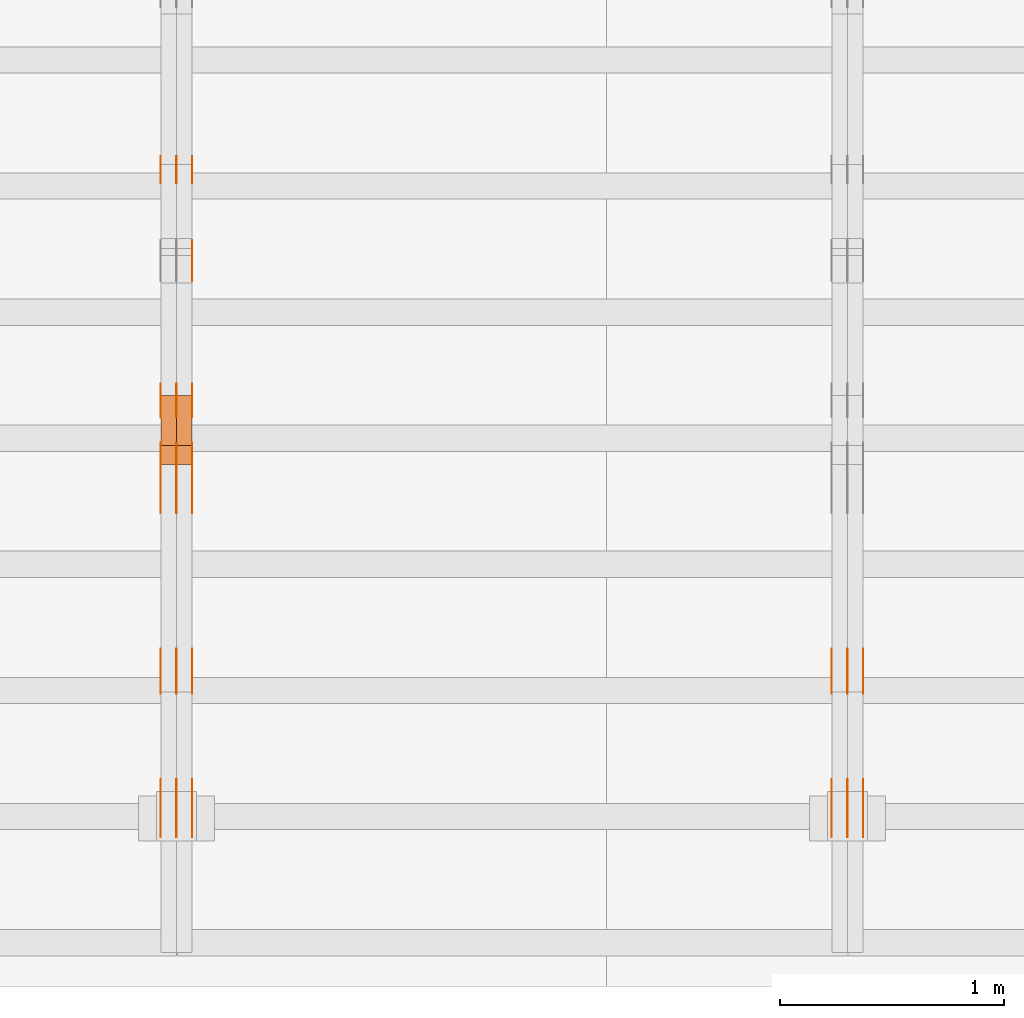
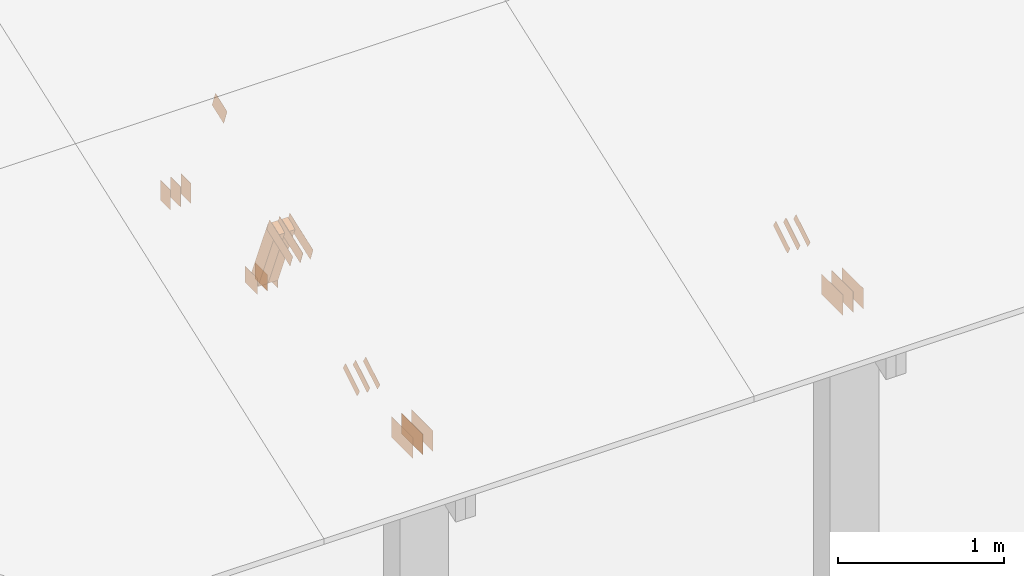
# One storey, part 84 of 189: 31 proxies.
"""IFC2X3 building model written with IfcOpenShell, lengths in millimetres."""

import ifcopenshell
import ifcopenshell.guid

model = None  # the IFC model being written
_history = None  # IfcOwnerHistory: only IFC2X3 demands one
_inside = {}  # id of a spatial element -> (the spatial element, [elements in it])
_under = {}  # id of a project, library or spatial element -> (it, [spatial elements below it])
_declared = {}  # id of a project -> (the project, [libraries it declares])
_typed = {}  # id of a type object -> (the type object, [elements of that type])
_made_of = {}  # id of a material, layer set ... -> (it, [elements and type objects made of it])


def new_model(schema):
    """Start an empty IFC model of exactly this schema.

    Asked for "IFC4X3", IfcOpenShell would pick the latest addendum, in which some entities
    have other attributes; the version numbers below select the first issue.
    IFC2X3 requires an IfcOwnerHistory on every rooted entity: one is made here for all.
    """
    global model, _history
    if schema == "IFC4X3":
        model = ifcopenshell.file(schema_version=(4, 3, 0, 0))
    else:
        model = ifcopenshell.file(schema=schema)
    _inside.clear()
    _under.clear()
    _declared.clear()
    _typed.clear()
    _made_of.clear()
    _history = None
    if model.schema == "IFC2X3":
        org = make("IfcOrganization", Name="unknown")
        user = make(
            "IfcPersonAndOrganization",
            ThePerson=make("IfcPerson", FamilyName="unknown"),
            TheOrganization=org,
        )
        app = make(
            "IfcApplication",
            ApplicationDeveloper=org,
            Version="unknown",
            ApplicationFullName="unknown",
            ApplicationIdentifier="unknown",
        )
        _history = make(
            "IfcOwnerHistory",
            OwningUser=user,
            OwningApplication=app,
            ChangeAction="ADDED",
            CreationDate=0,
        )
    return model


def make(cls, **values):
    """One entity of the class cls with the attributes given. An attribute that is None is left unset."""
    return model.create_entity(
        cls, **{name: value for name, value in values.items() if value is not None}
    )


def entity(cls, *values):
    """Any entity or typed value of the class cls, its attributes in the order of the schema. None: left unset."""
    e = model.create_entity(cls)
    for i, value in enumerate(values):
        if value is not None:
            e[i] = value
    return e


def rooted(cls, **values):
    """An entity with a GlobalId (a new one), such as an element, a storey or a relation."""
    return make(cls, GlobalId=ifcopenshell.guid.new(), OwnerHistory=_history, **values)


def si_unit(unit_type, name, prefix=None):
    """IfcSIUnit, for example si_unit("LENGTHUNIT", "METRE", prefix="MILLI")."""
    return make("IfcSIUnit", UnitType=unit_type, Prefix=prefix, Name=name)


def converted_unit(unit_type, name, factor, base, dimensions=None, offset=None):
    """IfcConversionBasedUnit, such as the inch: factor (a typed value) times the base unit."""
    return make(
        "IfcConversionBasedUnit"
        if offset is None
        else "IfcConversionBasedUnitWithOffset",
        ConversionOffset=offset,
        Dimensions=None
        if dimensions is None
        else entity("IfcDimensionalExponents", *dimensions),
        UnitType=unit_type,
        Name=name,
        ConversionFactor=make(
            "IfcMeasureWithUnit", ValueComponent=factor, UnitComponent=base
        ),
    )


def derived_unit(unit_type, elements):
    """IfcDerivedUnit: a product of units, each with its exponent."""
    return make(
        "IfcDerivedUnit",
        Elements=[
            make("IfcDerivedUnitElement", Unit=unit, Exponent=power)
            for unit, power in elements
        ],
        UnitType=unit_type,
    )


def assignment(units):
    """IfcUnitAssignment: the units of a project."""
    return None if units is None else make("IfcUnitAssignment", Units=units)


def point(xyz):
    """IfcCartesianPoint."""
    return None if xyz is None else make("IfcCartesianPoint", Coordinates=xyz)


def direction(xyz):
    """IfcDirection."""
    return None if xyz is None else make("IfcDirection", DirectionRatios=xyz)


def frame(location, z_axis=None, x_axis=None):
    """IfcAxis2Placement3D, a coordinate frame: its origin and axes. An axis left out is left unset."""
    return make(
        "IfcAxis2Placement3D",
        Location=point(location),
        Axis=direction(z_axis),
        RefDirection=direction(x_axis),
    )


def frame_2d(location, x_axis=None):
    """IfcAxis2Placement2D, a coordinate frame in the plane: its origin and x axis."""
    return make(
        "IfcAxis2Placement2D", Location=point(location), RefDirection=direction(x_axis)
    )


def origin():
    """The frame at (0, 0, 0) with its axes left unset."""
    return frame((0.0, 0.0, 0.0))


def origin_2d_with_axis():
    """The frame at (0, 0) in the plane with the x axis (1, 0) written out."""
    return frame_2d((0.0, 0.0), x_axis=(1.0, 0.0))


def place(relative_to, where):
    """IfcLocalPlacement: puts the frame where relative to a parent placement (None: the world)."""
    return make(
        "IfcLocalPlacement", PlacementRelTo=relative_to, RelativePlacement=where
    )


def context(
    kind, dimensions, precision=None, world=None, true_north=None, identifier=None
):
    """IfcGeometricRepresentationContext, for example the 3D "Model" context."""
    return make(
        "IfcGeometricRepresentationContext",
        ContextIdentifier=identifier,
        ContextType=kind,
        CoordinateSpaceDimension=dimensions,
        Precision=precision,
        WorldCoordinateSystem=world,
        TrueNorth=true_north,
    )


def subcontext(parent, identifier, kind, view, scale=None):
    """IfcGeometricRepresentationSubContext, for example "Body" below "Model"."""
    return make(
        "IfcGeometricRepresentationSubContext",
        ContextIdentifier=identifier,
        ContextType=kind,
        ParentContext=parent,
        TargetScale=scale,
        TargetView=view,
    )


def project(units=None, contexts=None):
    """IfcProject with its units and contexts."""
    return rooted(
        "IfcProject",
        Name="project",
        RepresentationContexts=contexts,
        UnitsInContext=assignment(units),
    )


def spatial(cls, under=None, at=None, **own):
    """A site, building, storey or space (cls), placed at a placement, below another one or the project."""
    s = rooted(cls, ObjectPlacement=at, **own)
    if under is not None:
        _under.setdefault(under.id(), (under, []))[1].append(s)
    return s


def polyline(points):
    """IfcPolyline through the points."""
    return make("IfcPolyline", Points=[point(p) for p in points])


def profile(cls, at=None, kind="AREA", **sizes):
    """A parametric profile (cls). Its sizes go by their IFC names, for example OverallWidth=200.0."""
    return make(cls, ProfileType=kind, Position=at, **sizes)


def rectangle(**sizes):
    """IfcRectangleProfileDef."""
    return profile("IfcRectangleProfileDef", **sizes)


def outline(outer, holes=None, kind="AREA"):
    """IfcArbitraryClosedProfileDef: a profile drawn as a closed curve; with holes, ...WithVoids."""
    if holes is None:
        return make("IfcArbitraryClosedProfileDef", ProfileType=kind, OuterCurve=outer)
    return make(
        "IfcArbitraryProfileDefWithVoids",
        ProfileType=kind,
        OuterCurve=outer,
        InnerCurves=holes,
    )


def extrude(swept, where, along, depth):
    """IfcExtrudedAreaSolid: the profile swept, set in the frame where, extruded along a direction by depth."""
    return make(
        "IfcExtrudedAreaSolid",
        SweptArea=swept,
        Position=where,
        ExtrudedDirection=direction(along),
        Depth=depth,
    )


def shape(context_of_items, identifier, shape_type, items):
    """IfcShapeRepresentation: the items that make up one representation, for example the "Body"."""
    return make(
        "IfcShapeRepresentation",
        ContextOfItems=context_of_items,
        RepresentationIdentifier=identifier,
        RepresentationType=shape_type,
        Items=items,
    )


def source(mapping_origin, context_of_items, identifier, shape_type, items):
    """IfcRepresentationMap: a shape defined once, which mapped items show again and again."""
    return make(
        "IfcRepresentationMap",
        MappingOrigin=mapping_origin,
        MappedRepresentation=shape(context_of_items, identifier, shape_type, items),
    )


def transform(
    local_origin,
    x_axis=None,
    y_axis=None,
    z_axis=None,
    scale=None,
    scale2=None,
    scale3=None,
    uniform=True,
):
    """IfcCartesianTransformationOperator3D, or its non-uniform kind. x_axis, y_axis, z_axis: its Axis1, 2, 3."""
    if uniform:
        return make(
            "IfcCartesianTransformationOperator3D",
            Axis1=direction(x_axis),
            Axis2=direction(y_axis),
            LocalOrigin=point(local_origin),
            Scale=scale,
            Axis3=direction(z_axis),
        )
    return make(
        "IfcCartesianTransformationOperator3DnonUniform",
        Axis1=direction(x_axis),
        Axis2=direction(y_axis),
        LocalOrigin=point(local_origin),
        Scale=scale,
        Axis3=direction(z_axis),
        Scale2=scale2,
        Scale3=scale3,
    )


def mapped(mapping_source, mapping_target):
    """IfcMappedItem: shows the shape of a source again, moved by a transform."""
    return make(
        "IfcMappedItem", MappingSource=mapping_source, MappingTarget=mapping_target
    )


def material(Name=None, Category=None):
    """IfcMaterial."""
    return make("IfcMaterial", Name=Name, Category=Category)


def made_of(thing, what):
    """Note that an element or type object is made of a material, layer set ...; save() writes the relation."""
    if what is not None:
        _made_of.setdefault(what.id(), (what, []))[1].append(thing)
    return thing


def type_object(cls, material=None, **own):
    """A type object (cls), such as IfcWallType, which elements share."""
    return made_of(rooted(cls, **own), material)


def type_shapes(of_type, sources):
    """Give a type object the sources (RepresentationMaps) that its elements show as mapped items."""
    of_type.RepresentationMaps = sources


def element(
    cls,
    number,
    at=None,
    inside=None,
    cuts=None,
    type_object=None,
    material=None,
    context=None,
    identifier="Body",
    shape_type=None,
    held_by="IfcProductDefinitionShape",
    body=None,
    shapes=None,
    **own,
):
    """One element of the class cls, such as IfcWall. Its Tag is "e" and its number.

    at: its placement. inside: the storey or other place that contains it. cuts: it is an
    opening in that element (IfcRelVoidsElement). A single representation is given by context,
    identifier, shape_type and body (its items); several are given by shapes. held_by: the class
    of the entity that holds the representations. save() writes the other relations.
    """
    e = rooted(cls, Tag="e%d" % number, ObjectPlacement=at, **own)
    if body is not None:
        shapes = [shape(context, identifier, shape_type, body)]
    if shapes is not None:
        e.Representation = make(held_by, Representations=shapes)
    if inside is not None:
        _inside.setdefault(inside.id(), (inside, []))[1].append(e)
    if cuts is not None:
        rooted(
            "IfcRelVoidsElement", RelatingBuildingElement=cuts, RelatedOpeningElement=e
        )
    if type_object is not None:
        _typed.setdefault(type_object.id(), (type_object, []))[1].append(e)
    return made_of(e, material)


def aggregate(whole, parts):
    """IfcRelAggregates: a whole, such as a stair, and the parts it consists of."""
    return rooted("IfcRelAggregates", RelatingObject=whole, RelatedObjects=parts)


def save(model, path):
    """Write the relations noted so far, then the file.

    IfcRelAggregates (storeys below a building ...), IfcRelContainedInSpatialStructure (elements
    in a storey), IfcRelDefinesByType, IfcRelAssociatesMaterial and IfcRelDeclares: one each for
    every whole, place, type object, material and project.
    """
    for whole, parts in _under.values():
        aggregate(whole, parts)
    for where, things in _inside.values():
        rooted(
            "IfcRelContainedInSpatialStructure",
            RelatedElements=things,
            RelatingStructure=where,
        )
    for kind, things in _typed.values():
        rooted("IfcRelDefinesByType", RelatedObjects=things, RelatingType=kind)
    for what, things in _made_of.values():
        rooted("IfcRelAssociatesMaterial", RelatedObjects=things, RelatingMaterial=what)
    for by, libraries in _declared.values():
        rooted("IfcRelDeclares", RelatingContext=by, RelatedDefinitions=libraries)
    model.write(path)


model = new_model("IFC2X3")

# Units and contexts
model_context = context("Model", 3, precision=0.01, world=origin(), true_north=direction((6.12303176911189e-17, 1.0)))
body_context = subcontext(model_context, "Body", "Model", "MODEL_VIEW")
ifc_project = project(units=[si_unit("LENGTHUNIT", "METRE", prefix="MILLI"), si_unit("AREAUNIT", "SQUARE_METRE"), si_unit("VOLUMEUNIT", "CUBIC_METRE"), converted_unit("PLANEANGLEUNIT", "DEGREE", entity("IfcRatioMeasure", 0.0174532925199433), si_unit("PLANEANGLEUNIT", "RADIAN"), dimensions=[0, 0, 0, 0, 0, 0, 0]), si_unit("MASSUNIT", "GRAM", prefix="KILO"), derived_unit("MASSDENSITYUNIT", [(si_unit("MASSUNIT", "GRAM", prefix="KILO"), 1), (si_unit("LENGTHUNIT", "METRE"), -3)]), si_unit("TIMEUNIT", "SECOND"), si_unit("FREQUENCYUNIT", "HERTZ"), si_unit("THERMODYNAMICTEMPERATUREUNIT", "DEGREE_CELSIUS"), derived_unit("THERMALTRANSMITTANCEUNIT", [(si_unit("MASSUNIT", "GRAM", prefix="KILO"), 1), (si_unit("THERMODYNAMICTEMPERATUREUNIT", "KELVIN"), -1), (si_unit("TIMEUNIT", "SECOND"), -3)]), derived_unit("VOLUMETRICFLOWRATEUNIT", [(si_unit("LENGTHUNIT", "METRE"), 3), (si_unit("TIMEUNIT", "SECOND"), -1)]), si_unit("ELECTRICCURRENTUNIT", "AMPERE"), si_unit("ELECTRICVOLTAGEUNIT", "VOLT"), si_unit("POWERUNIT", "WATT"), si_unit("FORCEUNIT", "NEWTON"), si_unit("ILLUMINANCEUNIT", "LUX"), si_unit("LUMINOUSFLUXUNIT", "LUMEN"), si_unit("LUMINOUSINTENSITYUNIT", "CANDELA"), derived_unit("USERDEFINED", [(si_unit("MASSUNIT", "GRAM", prefix="KILO"), -1), (si_unit("LENGTHUNIT", "METRE"), -2), (si_unit("TIMEUNIT", "SECOND"), 3), (si_unit("LUMINOUSFLUXUNIT", "LUMEN"), 1)]), derived_unit("LINEARVELOCITYUNIT", [(si_unit("LENGTHUNIT", "METRE"), 1), (si_unit("TIMEUNIT", "SECOND"), -1)]), si_unit("PRESSUREUNIT", "PASCAL"), derived_unit("USERDEFINED", [(si_unit("LENGTHUNIT", "METRE"), -2), (si_unit("MASSUNIT", "GRAM", prefix="KILO"), 1), (si_unit("TIMEUNIT", "SECOND"), -2)])], contexts=[model_context])

# Site, building, storey
site_placement = place(None, origin())
site = spatial("IfcSite", under=ifc_project, at=site_placement, CompositionType="ELEMENT")
building_placement = place(site_placement, origin())
building = spatial("IfcBuilding", under=site, at=building_placement, CompositionType="ELEMENT")
storey_placement = place(building_placement, origin())
storey = spatial("IfcBuildingStorey", under=building, at=storey_placement, Name="Default", CompositionType="ELEMENT", Elevation=0.0)

# Proxies
ifc_material_1 = material(Name="IfcSurfaceStyle #103286")
building_element_proxy_type_1 = type_object("IfcBuildingElementProxyType", PredefinedType="NOTDEFINED", material=ifc_material_1)
shared_shape_1 = source(origin(), body_context, "Body", "SweptSolid", [
    extrude(outline(polyline([(-100.000388510424, -29.9995882393532), (100.000691805256, -29.9995882393532), (100.000392424258, 29.9995882393532), (-100.00069571909, 29.9995882393532), (-100.000388510424, -29.9995882393532)])), frame((100.000691805256, 30.0002299338894, 0.0), z_axis=(0.0, 0.0, 1.0), x_axis=(-1.0, 0.0, 0.0)), (0.0, 0.0, 1.0), 1.3),
])
type_shapes(building_element_proxy_type_1, [shared_shape_1])
proxy_1_placement = place(building_placement, frame((18301.3, 656.945055513712, 219.45219322107), z_axis=(-1.0, 0.0, 0.0), x_axis=(0.0, 0.858392121304013, 0.51299411895576)))
element("IfcBuildingElementProxy", 1, at=proxy_1_placement, inside=storey, type_object=building_element_proxy_type_1, material=ifc_material_1, context=body_context, shape_type="MappedRepresentation", body=[
    mapped(shared_shape_1, transform((0.0, 0.0, 0.0), scale=1.0)),
])
ifc_material_2 = material(Name="IfcSurfaceStyle #103229")
building_element_proxy_type_2 = type_object("IfcBuildingElementProxyType", PredefinedType="NOTDEFINED", material=ifc_material_2)
shared_shape_2 = source(origin(), body_context, "Body", "SweptSolid", [
    extrude(outline(polyline([(-100.000388510424, -29.9995882393532), (100.000691805256, -29.9995882393532), (100.000392424258, 29.9995882393532), (-100.00069571909, 29.9995882393532), (-100.000388510424, -29.9995882393532)])), frame((100.000691805256, 30.0002299338894, 0.0), z_axis=(0.0, 0.0, 1.0), x_axis=(-1.0, 0.0, 0.0)), (0.0, 0.0, 1.0), 1.29999999999998),
])
type_shapes(building_element_proxy_type_2, [shared_shape_2])
proxy_2_placement = place(building_placement, frame((18230.0, 656.945055513712, 219.45219322107), z_axis=(-1.0, 0.0, 0.0), x_axis=(0.0, 0.858392121304013, 0.51299411895576)))
element("IfcBuildingElementProxy", 2, at=proxy_2_placement, inside=storey, type_object=building_element_proxy_type_2, material=ifc_material_2, context=body_context, shape_type="MappedRepresentation", body=[
    mapped(shared_shape_2, transform((0.0, 0.0, 0.0), scale=1.0)),
])
ifc_material_3 = material(Name="IfcSurfaceStyle #103172")
building_element_proxy_type_3 = type_object("IfcBuildingElementProxyType", PredefinedType="NOTDEFINED", material=ifc_material_3)
shared_shape_3 = source(origin(), body_context, "Body", "SweptSolid", [
    extrude(outline(polyline([(-100.000388510424, -29.9995882393532), (100.000691805256, -29.9995882393532), (100.000392424258, 29.9995882393532), (-100.00069571909, 29.9995882393532), (-100.000388510424, -29.9995882393532)])), frame((100.000691805256, 30.0002299338894, 0.0), z_axis=(0.0, 0.0, 1.0), x_axis=(-1.0, 0.0, 0.0)), (0.0, 0.0, 1.0), 1.29999999999998),
])
type_shapes(building_element_proxy_type_3, [shared_shape_3])
proxy_3_placement = place(building_placement, frame((18231.3, 656.945055513712, 219.45219322107), z_axis=(-1.0, 0.0, 0.0), x_axis=(0.0, 0.858392121304013, 0.51299411895576)))
element("IfcBuildingElementProxy", 3, at=proxy_3_placement, inside=storey, type_object=building_element_proxy_type_3, material=ifc_material_3, context=body_context, shape_type="MappedRepresentation", body=[
    mapped(shared_shape_3, transform((0.0, 0.0, 0.0), scale=1.0)),
])
ifc_material_4 = material(Name="IfcSurfaceStyle #103115")
building_element_proxy_type_4 = type_object("IfcBuildingElementProxyType", PredefinedType="NOTDEFINED", material=ifc_material_4)
shared_shape_4 = source(origin(), body_context, "Body", "SweptSolid", [
    extrude(outline(polyline([(-100.000388510424, -29.9995882393532), (100.000691805256, -29.9995882393532), (100.000392424258, 29.9995882393532), (-100.00069571909, 29.9995882393532), (-100.000388510424, -29.9995882393532)])), frame((100.000691805256, 30.0002299338894, 0.0), z_axis=(0.0, 0.0, 1.0), x_axis=(-1.0, 0.0, 0.0)), (0.0, 0.0, 1.0), 1.29999999999999),
])
type_shapes(building_element_proxy_type_4, [shared_shape_4])
proxy_4_placement = place(building_placement, frame((18160.0, 656.945055513712, 219.45219322107), z_axis=(-1.0, 0.0, 0.0), x_axis=(0.0, 0.858392121304013, 0.51299411895576)))
element("IfcBuildingElementProxy", 4, at=proxy_4_placement, inside=storey, type_object=building_element_proxy_type_4, material=ifc_material_4, context=body_context, shape_type="MappedRepresentation", body=[
    mapped(shared_shape_4, transform((0.0, 0.0, 0.0), scale=1.0)),
])
ifc_material_5 = material(Name="IfcSurfaceStyle #101750")
building_element_proxy_type_5 = type_object("IfcBuildingElementProxyType", PredefinedType="NOTDEFINED", material=ifc_material_5)
shared_shape_5 = source(origin(), body_context, "Body", "SweptSolid", [
    extrude(rectangle(XDim=258.0, YDim=151.999992370605, at=origin_2d_with_axis()), frame((129.0, 76.0000049445079, 0.0), z_axis=(0.0, 0.0, 1.0), x_axis=(-1.0, 0.0, 0.0)), (0.0, 0.0, 1.0), 0.999999999999984),
])
type_shapes(building_element_proxy_type_5, [shared_shape_5])
proxy_5_placement = place(building_placement, frame((18301.0, 16.236328125, 268.138222870533), z_axis=(-1.0, 0.0, 0.0), x_axis=(0.0, 1.0, 0.0)))
element("IfcBuildingElementProxy", 5, at=proxy_5_placement, inside=storey, type_object=building_element_proxy_type_5, material=ifc_material_5, Name="GNT100S 152x258", context=body_context, shape_type="MappedRepresentation", body=[
    mapped(shared_shape_5, transform((0.0, 0.0, 0.0), scale=1.0)),
])
ifc_material_6 = material(Name="IfcSurfaceStyle #101693")
building_element_proxy_type_6 = type_object("IfcBuildingElementProxyType", PredefinedType="NOTDEFINED", material=ifc_material_6)
shared_shape_6 = source(origin(), body_context, "Body", "SweptSolid", [
    extrude(rectangle(XDim=258.0, YDim=151.999992370605, at=origin_2d_with_axis()), frame((129.0, 76.0000049445079, 0.0), z_axis=(0.0, 0.0, 1.0), x_axis=(-1.0, 0.0, 0.0)), (0.0, 0.0, 1.0), 0.999999999999984),
])
type_shapes(building_element_proxy_type_6, [shared_shape_6])
proxy_6_placement = place(building_placement, frame((18230.0, 16.236328125, 268.138222870533), z_axis=(-1.0, 0.0, 0.0), x_axis=(0.0, 1.0, 0.0)))
element("IfcBuildingElementProxy", 6, at=proxy_6_placement, inside=storey, type_object=building_element_proxy_type_6, material=ifc_material_6, Name="GNT100S 152x258", context=body_context, shape_type="MappedRepresentation", body=[
    mapped(shared_shape_6, transform((0.0, 0.0, 0.0), scale=1.0)),
])
ifc_material_7 = material(Name="IfcSurfaceStyle #101636")
building_element_proxy_type_7 = type_object("IfcBuildingElementProxyType", PredefinedType="NOTDEFINED", material=ifc_material_7)
shared_shape_7 = source(origin(), body_context, "Body", "SweptSolid", [
    extrude(rectangle(XDim=258.0, YDim=151.999992370605, at=origin_2d_with_axis()), frame((129.0, 76.0000049445079, 0.0), z_axis=(0.0, 0.0, 1.0), x_axis=(-1.0, 0.0, 0.0)), (0.0, 0.0, 1.0), 0.999999999999984),
])
type_shapes(building_element_proxy_type_7, [shared_shape_7])
proxy_7_placement = place(building_placement, frame((18231.0, 16.236328125, 268.138222870533), z_axis=(-1.0, 0.0, 0.0), x_axis=(0.0, 1.0, 0.0)))
element("IfcBuildingElementProxy", 7, at=proxy_7_placement, inside=storey, type_object=building_element_proxy_type_7, material=ifc_material_7, Name="GNT100S 152x258", context=body_context, shape_type="MappedRepresentation", body=[
    mapped(shared_shape_7, transform((0.0, 0.0, 0.0), scale=1.0)),
])
ifc_material_8 = material(Name="IfcSurfaceStyle #101579")
building_element_proxy_type_8 = type_object("IfcBuildingElementProxyType", PredefinedType="NOTDEFINED", material=ifc_material_8)
shared_shape_8 = source(origin(), body_context, "Body", "SweptSolid", [
    extrude(rectangle(XDim=258.0, YDim=151.999992370605, at=origin_2d_with_axis()), frame((129.0, 76.0000049445079, 0.0), z_axis=(0.0, 0.0, 1.0), x_axis=(-1.0, 0.0, 0.0)), (0.0, 0.0, 1.0), 0.999999999999984),
])
type_shapes(building_element_proxy_type_8, [shared_shape_8])
proxy_8_placement = place(building_placement, frame((18160.0, 16.236328125, 268.138222870533), z_axis=(-1.0, 0.0, 0.0), x_axis=(0.0, 1.0, 0.0)))
element("IfcBuildingElementProxy", 8, at=proxy_8_placement, inside=storey, type_object=building_element_proxy_type_8, material=ifc_material_8, Name="GNT100S 152x258", context=body_context, shape_type="MappedRepresentation", body=[
    mapped(shared_shape_8, transform((0.0, 0.0, 0.0), scale=1.0)),
])
ifc_material_9 = material(Name="IfcSurfaceStyle #89320")
building_element_proxy_type_9 = type_object("IfcBuildingElementProxyType", PredefinedType="NOTDEFINED", material=ifc_material_9)
shared_shape_9 = source(origin(), body_context, "Body", "SweptSolid", [
    extrude(rectangle(XDim=150.0, YDim=120.0, at=frame_2d((1.4210854715202e-14, -7.105427357601e-15), x_axis=(1.0, 0.0))), frame((75.0, 60.0004961323721, 0.0), z_axis=(0.0, 0.0, 1.0), x_axis=(-1.0, 0.0, 0.0)), (0.0, 0.0, 1.0), 1.3),
])
type_shapes(building_element_proxy_type_9, [shared_shape_9])
proxy_9_placement = place(building_placement, frame((15301.3, 2940.99169136763, 170.0), z_axis=(-1.0, 0.0, 0.0), x_axis=(0.0, 0.0, 1.0)))
element("IfcBuildingElementProxy", 9, at=proxy_9_placement, inside=storey, type_object=building_element_proxy_type_9, material=ifc_material_9, context=body_context, shape_type="MappedRepresentation", body=[
    mapped(shared_shape_9, transform((0.0, 0.0, 0.0), scale=1.0)),
])
ifc_material_10 = material(Name="IfcSurfaceStyle #89263")
building_element_proxy_type_10 = type_object("IfcBuildingElementProxyType", PredefinedType="NOTDEFINED", material=ifc_material_10)
shared_shape_10 = source(origin(), body_context, "Body", "SweptSolid", [
    extrude(rectangle(XDim=150.0, YDim=120.0, at=frame_2d((1.4210854715202e-14, -7.105427357601e-15), x_axis=(1.0, 0.0))), frame((75.0, 60.0004961323721, 0.0), z_axis=(0.0, 0.0, 1.0), x_axis=(-1.0, 0.0, 0.0)), (0.0, 0.0, 1.0), 1.29999999999999),
])
type_shapes(building_element_proxy_type_10, [shared_shape_10])
proxy_10_placement = place(building_placement, frame((15230.0, 2940.99169136763, 170.0), z_axis=(-1.0, 0.0, 0.0), x_axis=(0.0, 0.0, 1.0)))
element("IfcBuildingElementProxy", 10, at=proxy_10_placement, inside=storey, type_object=building_element_proxy_type_10, material=ifc_material_10, context=body_context, shape_type="MappedRepresentation", body=[
    mapped(shared_shape_10, transform((0.0, 0.0, 0.0), scale=1.0)),
])
ifc_material_11 = material(Name="IfcSurfaceStyle #89206")
building_element_proxy_type_11 = type_object("IfcBuildingElementProxyType", PredefinedType="NOTDEFINED", material=ifc_material_11)
shared_shape_11 = source(origin(), body_context, "Body", "SweptSolid", [
    extrude(rectangle(XDim=150.0, YDim=120.0, at=frame_2d((1.4210854715202e-14, -7.105427357601e-15), x_axis=(1.0, 0.0))), frame((75.0, 60.0004961323721, 0.0), z_axis=(0.0, 0.0, 1.0), x_axis=(-1.0, 0.0, 0.0)), (0.0, 0.0, 1.0), 1.29999999999999),
])
type_shapes(building_element_proxy_type_11, [shared_shape_11])
proxy_11_placement = place(building_placement, frame((15231.3, 2940.99169136763, 170.0), z_axis=(-1.0, 0.0, 0.0), x_axis=(0.0, 0.0, 1.0)))
element("IfcBuildingElementProxy", 11, at=proxy_11_placement, inside=storey, type_object=building_element_proxy_type_11, material=ifc_material_11, context=body_context, shape_type="MappedRepresentation", body=[
    mapped(shared_shape_11, transform((0.0, 0.0, 0.0), scale=1.0)),
])
ifc_material_12 = material(Name="IfcSurfaceStyle #89149")
building_element_proxy_type_12 = type_object("IfcBuildingElementProxyType", PredefinedType="NOTDEFINED", material=ifc_material_12)
shared_shape_12 = source(origin(), body_context, "Body", "SweptSolid", [
    extrude(rectangle(XDim=150.0, YDim=120.0, at=frame_2d((1.4210854715202e-14, -7.105427357601e-15), x_axis=(1.0, 0.0))), frame((75.0, 60.0004961323721, 0.0), z_axis=(0.0, 0.0, 1.0), x_axis=(-1.0, 0.0, 0.0)), (0.0, 0.0, 1.0), 1.29999999999999),
])
type_shapes(building_element_proxy_type_12, [shared_shape_12])
proxy_12_placement = place(building_placement, frame((15160.0, 2940.99169136763, 170.0), z_axis=(-1.0, 0.0, 0.0), x_axis=(0.0, 0.0, 1.0)))
element("IfcBuildingElementProxy", 12, at=proxy_12_placement, inside=storey, type_object=building_element_proxy_type_12, material=ifc_material_12, context=body_context, shape_type="MappedRepresentation", body=[
    mapped(shared_shape_12, transform((0.0, 0.0, 0.0), scale=1.0)),
])
ifc_material_13 = material(Name="IfcSurfaceStyle #89092")
building_element_proxy_type_13 = type_object("IfcBuildingElementProxyType", PredefinedType="NOTDEFINED", material=ifc_material_13)
shared_shape_13 = source(origin(), body_context, "Body", "SweptSolid", [
    extrude(outline(polyline([(-75.0008071857483, -59.9999039432187), (75.0002916555677, -59.9999039432187), (75.0008280609982, 59.9999039432187), (-75.0003125308176, 59.9999039432187), (-75.0008071857483, -59.9999039432187)])), frame((75.0008280609982, 60.0002349219685, 0.0), z_axis=(0.0, 0.0, 1.0), x_axis=(-1.0, 0.0, 0.0)), (0.0, 0.0, 1.0), 1.3),
])
type_shapes(building_element_proxy_type_13, [shared_shape_13])
proxy_13_placement = place(building_placement, frame((15301.3, 2502.466796875, 1113.95080566406), z_axis=(-1.0, 0.0, 0.0), x_axis=(0.0, 0.939692620785908, 0.342020143325669)))
element("IfcBuildingElementProxy", 13, at=proxy_13_placement, inside=storey, type_object=building_element_proxy_type_13, material=ifc_material_13, context=body_context, shape_type="MappedRepresentation", body=[
    mapped(shared_shape_13, transform((0.0, 0.0, 0.0), scale=1.0)),
])
ifc_material_14 = material(Name="IfcSurfaceStyle #88408")
building_element_proxy_type_14 = type_object("IfcBuildingElementProxyType", PredefinedType="NOTDEFINED", material=ifc_material_14)
shared_shape_14 = source(origin(), body_context, "Body", "SweptSolid", [
    extrude(rectangle(XDim=150.0, YDim=120.0, at=origin_2d_with_axis()), frame((75.0004757715869, 60.0, 0.0), z_axis=(0.0, 0.0, 1.0), x_axis=(-1.0, 0.0, 0.0)), (0.0, 0.0, 1.0), 1.3),
])
type_shapes(building_element_proxy_type_14, [shared_shape_14])
proxy_14_placement = place(building_placement, frame((15301.3, 1892.68702422841, 305.0), z_axis=(-1.0, 0.0, 0.0), x_axis=(0.0, 1.0, 0.0)))
element("IfcBuildingElementProxy", 14, at=proxy_14_placement, inside=storey, type_object=building_element_proxy_type_14, material=ifc_material_14, context=body_context, shape_type="MappedRepresentation", body=[
    mapped(shared_shape_14, transform((0.0, 0.0, 0.0), scale=1.0)),
])
ifc_material_15 = material(Name="IfcSurfaceStyle #88351")
building_element_proxy_type_15 = type_object("IfcBuildingElementProxyType", PredefinedType="NOTDEFINED", material=ifc_material_15)
shared_shape_15 = source(origin(), body_context, "Body", "SweptSolid", [
    extrude(rectangle(XDim=150.0, YDim=120.0, at=origin_2d_with_axis()), frame((75.0004757715869, 60.0, 0.0), z_axis=(0.0, 0.0, 1.0), x_axis=(-1.0, 0.0, 0.0)), (0.0, 0.0, 1.0), 1.29999999999999),
])
type_shapes(building_element_proxy_type_15, [shared_shape_15])
proxy_15_placement = place(building_placement, frame((15230.0, 1892.68702422841, 305.0), z_axis=(-1.0, 0.0, 0.0), x_axis=(0.0, 1.0, 0.0)))
element("IfcBuildingElementProxy", 15, at=proxy_15_placement, inside=storey, type_object=building_element_proxy_type_15, material=ifc_material_15, context=body_context, shape_type="MappedRepresentation", body=[
    mapped(shared_shape_15, transform((0.0, 0.0, 0.0), scale=1.0)),
])
ifc_material_16 = material(Name="IfcSurfaceStyle #88294")
building_element_proxy_type_16 = type_object("IfcBuildingElementProxyType", PredefinedType="NOTDEFINED", material=ifc_material_16)
shared_shape_16 = source(origin(), body_context, "Body", "SweptSolid", [
    extrude(rectangle(XDim=150.0, YDim=120.0, at=origin_2d_with_axis()), frame((75.0004757715869, 60.0, 0.0), z_axis=(0.0, 0.0, 1.0), x_axis=(-1.0, 0.0, 0.0)), (0.0, 0.0, 1.0), 1.29999999999999),
])
type_shapes(building_element_proxy_type_16, [shared_shape_16])
proxy_16_placement = place(building_placement, frame((15231.3, 1892.68702422841, 305.0), z_axis=(-1.0, 0.0, 0.0), x_axis=(0.0, 1.0, 0.0)))
element("IfcBuildingElementProxy", 16, at=proxy_16_placement, inside=storey, type_object=building_element_proxy_type_16, material=ifc_material_16, context=body_context, shape_type="MappedRepresentation", body=[
    mapped(shared_shape_16, transform((0.0, 0.0, 0.0), scale=1.0)),
])
ifc_material_17 = material(Name="IfcSurfaceStyle #88237")
building_element_proxy_type_17 = type_object("IfcBuildingElementProxyType", PredefinedType="NOTDEFINED", material=ifc_material_17)
shared_shape_17 = source(origin(), body_context, "Body", "SweptSolid", [
    extrude(rectangle(XDim=150.0, YDim=120.0, at=origin_2d_with_axis()), frame((75.0004757715869, 60.0, 0.0), z_axis=(0.0, 0.0, 1.0), x_axis=(-1.0, 0.0, 0.0)), (0.0, 0.0, 1.0), 1.29999999999999),
])
type_shapes(building_element_proxy_type_17, [shared_shape_17])
proxy_17_placement = place(building_placement, frame((15160.0, 1892.68702422841, 305.0), z_axis=(-1.0, 0.0, 0.0), x_axis=(0.0, 1.0, 0.0)))
element("IfcBuildingElementProxy", 17, at=proxy_17_placement, inside=storey, type_object=building_element_proxy_type_17, material=ifc_material_17, context=body_context, shape_type="MappedRepresentation", body=[
    mapped(shared_shape_17, transform((0.0, 0.0, 0.0), scale=1.0)),
])
ifc_material_18 = material(Name="IfcSurfaceStyle #88180")
building_element_proxy_type_18 = type_object("IfcBuildingElementProxyType", PredefinedType="NOTDEFINED", material=ifc_material_18)
shared_shape_18 = source(origin(), body_context, "Body", "SweptSolid", [
    extrude(outline(polyline([(-150.000217420008, -47.9999344162752), (150.000165800718, -47.9999344162752), (150.000227857633, 47.9999344162752), (-150.000176238343, 47.9999344162752), (-150.000217420008, -47.9999344162752)])), frame((150.000227857633, 48.0000430742566, 0.0), z_axis=(0.0, 0.0, 1.0), x_axis=(-1.0, 0.0, 0.0)), (0.0, 0.0, 1.0), 1.29999999999999),
])
type_shapes(building_element_proxy_type_18, [shared_shape_18])
proxy_18_placement = place(building_placement, frame((15301.3, 1464.46484375, 723.378723144533), z_axis=(-1.0, 0.0, 0.0), x_axis=(0.0, 0.939692620785908, 0.342020143325669)))
element("IfcBuildingElementProxy", 18, at=proxy_18_placement, inside=storey, type_object=building_element_proxy_type_18, material=ifc_material_18, context=body_context, shape_type="MappedRepresentation", body=[
    mapped(shared_shape_18, transform((0.0, 0.0, 0.0), scale=1.0)),
])
ifc_material_19 = material(Name="IfcSurfaceStyle #88123")
building_element_proxy_type_19 = type_object("IfcBuildingElementProxyType", PredefinedType="NOTDEFINED", material=ifc_material_19)
shared_shape_19 = source(origin(), body_context, "Body", "SweptSolid", [
    extrude(outline(polyline([(-150.000217420008, -47.9999344162752), (150.000165800718, -47.9999344162752), (150.000227857633, 47.9999344162752), (-150.000176238343, 47.9999344162752), (-150.000217420008, -47.9999344162752)])), frame((150.000227857633, 48.0000430742566, 0.0), z_axis=(0.0, 0.0, 1.0), x_axis=(-1.0, 0.0, 0.0)), (0.0, 0.0, 1.0), 1.29999999999998),
])
type_shapes(building_element_proxy_type_19, [shared_shape_19])
proxy_19_placement = place(building_placement, frame((15230.0, 1464.46484375, 723.378723144533), z_axis=(-1.0, 0.0, 0.0), x_axis=(0.0, 0.939692620785908, 0.342020143325669)))
element("IfcBuildingElementProxy", 19, at=proxy_19_placement, inside=storey, type_object=building_element_proxy_type_19, material=ifc_material_19, context=body_context, shape_type="MappedRepresentation", body=[
    mapped(shared_shape_19, transform((0.0, 0.0, 0.0), scale=1.0)),
])
ifc_material_20 = material(Name="IfcSurfaceStyle #88066")
building_element_proxy_type_20 = type_object("IfcBuildingElementProxyType", PredefinedType="NOTDEFINED", material=ifc_material_20)
shared_shape_20 = source(origin(), body_context, "Body", "SweptSolid", [
    extrude(outline(polyline([(-150.000217420008, -47.9999344162752), (150.000165800718, -47.9999344162752), (150.000227857633, 47.9999344162752), (-150.000176238343, 47.9999344162752), (-150.000217420008, -47.9999344162752)])), frame((150.000227857633, 48.0000430742566, 0.0), z_axis=(0.0, 0.0, 1.0), x_axis=(-1.0, 0.0, 0.0)), (0.0, 0.0, 1.0), 1.29999999999998),
])
type_shapes(building_element_proxy_type_20, [shared_shape_20])
proxy_20_placement = place(building_placement, frame((15231.3, 1464.46484375, 723.378723144533), z_axis=(-1.0, 0.0, 0.0), x_axis=(0.0, 0.939692620785908, 0.342020143325669)))
element("IfcBuildingElementProxy", 20, at=proxy_20_placement, inside=storey, type_object=building_element_proxy_type_20, material=ifc_material_20, context=body_context, shape_type="MappedRepresentation", body=[
    mapped(shared_shape_20, transform((0.0, 0.0, 0.0), scale=1.0)),
])
ifc_material_21 = material(Name="IfcSurfaceStyle #88009")
building_element_proxy_type_21 = type_object("IfcBuildingElementProxyType", PredefinedType="NOTDEFINED", material=ifc_material_21)
shared_shape_21 = source(origin(), body_context, "Body", "SweptSolid", [
    extrude(outline(polyline([(-150.000217420008, -47.9999344162752), (150.000165800718, -47.9999344162752), (150.000227857633, 47.9999344162752), (-150.000176238343, 47.9999344162752), (-150.000217420008, -47.9999344162752)])), frame((150.000227857633, 48.0000430742566, 0.0), z_axis=(0.0, 0.0, 1.0), x_axis=(-1.0, 0.0, 0.0)), (0.0, 0.0, 1.0), 1.29999999999998),
])
type_shapes(building_element_proxy_type_21, [shared_shape_21])
proxy_21_placement = place(building_placement, frame((15160.0, 1464.46484375, 723.378723144533), z_axis=(-1.0, 0.0, 0.0), x_axis=(0.0, 0.939692620785908, 0.342020143325669)))
element("IfcBuildingElementProxy", 21, at=proxy_21_placement, inside=storey, type_object=building_element_proxy_type_21, material=ifc_material_21, context=body_context, shape_type="MappedRepresentation", body=[
    mapped(shared_shape_21, transform((0.0, 0.0, 0.0), scale=1.0)),
])
ifc_material_22 = material(Name="IfcSurfaceStyle #87496")
building_element_proxy_type_22 = type_object("IfcBuildingElementProxyType", PredefinedType="NOTDEFINED", material=ifc_material_22)
shared_shape_22 = source(origin(), body_context, "Body", "SweptSolid", [
    extrude(outline(polyline([(-100.000388510424, -29.9995882393532), (100.000691805256, -29.9995882393532), (100.000392424258, 29.9995882393532), (-100.00069571909, 29.9995882393532), (-100.000388510424, -29.9995882393532)])), frame((100.000691805256, 30.0002299338894, 0.0), z_axis=(0.0, 0.0, 1.0), x_axis=(-1.0, 0.0, 0.0)), (0.0, 0.0, 1.0), 1.3),
])
type_shapes(building_element_proxy_type_22, [shared_shape_22])
proxy_22_placement = place(building_placement, frame((15301.3, 656.945055513712, 219.45219322107), z_axis=(-1.0, 0.0, 0.0), x_axis=(0.0, 0.858392121304013, 0.51299411895576)))
element("IfcBuildingElementProxy", 22, at=proxy_22_placement, inside=storey, type_object=building_element_proxy_type_22, material=ifc_material_22, context=body_context, shape_type="MappedRepresentation", body=[
    mapped(shared_shape_22, transform((0.0, 0.0, 0.0), scale=1.0)),
])
ifc_material_23 = material(Name="IfcSurfaceStyle #87439")
building_element_proxy_type_23 = type_object("IfcBuildingElementProxyType", PredefinedType="NOTDEFINED", material=ifc_material_23)
shared_shape_23 = source(origin(), body_context, "Body", "SweptSolid", [
    extrude(outline(polyline([(-100.000388510424, -29.9995882393532), (100.000691805256, -29.9995882393532), (100.000392424258, 29.9995882393532), (-100.00069571909, 29.9995882393532), (-100.000388510424, -29.9995882393532)])), frame((100.000691805256, 30.0002299338894, 0.0), z_axis=(0.0, 0.0, 1.0), x_axis=(-1.0, 0.0, 0.0)), (0.0, 0.0, 1.0), 1.29999999999998),
])
type_shapes(building_element_proxy_type_23, [shared_shape_23])
proxy_23_placement = place(building_placement, frame((15230.0, 656.945055513712, 219.45219322107), z_axis=(-1.0, 0.0, 0.0), x_axis=(0.0, 0.858392121304013, 0.51299411895576)))
element("IfcBuildingElementProxy", 23, at=proxy_23_placement, inside=storey, type_object=building_element_proxy_type_23, material=ifc_material_23, context=body_context, shape_type="MappedRepresentation", body=[
    mapped(shared_shape_23, transform((0.0, 0.0, 0.0), scale=1.0)),
])
ifc_material_24 = material(Name="IfcSurfaceStyle #87382")
building_element_proxy_type_24 = type_object("IfcBuildingElementProxyType", PredefinedType="NOTDEFINED", material=ifc_material_24)
shared_shape_24 = source(origin(), body_context, "Body", "SweptSolid", [
    extrude(outline(polyline([(-100.000388510424, -29.9995882393532), (100.000691805256, -29.9995882393532), (100.000392424258, 29.9995882393532), (-100.00069571909, 29.9995882393532), (-100.000388510424, -29.9995882393532)])), frame((100.000691805256, 30.0002299338894, 0.0), z_axis=(0.0, 0.0, 1.0), x_axis=(-1.0, 0.0, 0.0)), (0.0, 0.0, 1.0), 1.29999999999998),
])
type_shapes(building_element_proxy_type_24, [shared_shape_24])
proxy_24_placement = place(building_placement, frame((15231.3, 656.945055513712, 219.45219322107), z_axis=(-1.0, 0.0, 0.0), x_axis=(0.0, 0.858392121304013, 0.51299411895576)))
element("IfcBuildingElementProxy", 24, at=proxy_24_placement, inside=storey, type_object=building_element_proxy_type_24, material=ifc_material_24, context=body_context, shape_type="MappedRepresentation", body=[
    mapped(shared_shape_24, transform((0.0, 0.0, 0.0), scale=1.0)),
])
ifc_material_25 = material(Name="IfcSurfaceStyle #87325")
building_element_proxy_type_25 = type_object("IfcBuildingElementProxyType", PredefinedType="NOTDEFINED", material=ifc_material_25)
shared_shape_25 = source(origin(), body_context, "Body", "SweptSolid", [
    extrude(outline(polyline([(-100.000388510424, -29.9995882393532), (100.000691805256, -29.9995882393532), (100.000392424258, 29.9995882393532), (-100.00069571909, 29.9995882393532), (-100.000388510424, -29.9995882393532)])), frame((100.000691805256, 30.0002299338894, 0.0), z_axis=(0.0, 0.0, 1.0), x_axis=(-1.0, 0.0, 0.0)), (0.0, 0.0, 1.0), 1.29999999999999),
])
type_shapes(building_element_proxy_type_25, [shared_shape_25])
proxy_25_placement = place(building_placement, frame((15160.0, 656.945055513712, 219.45219322107), z_axis=(-1.0, 0.0, 0.0), x_axis=(0.0, 0.858392121304013, 0.51299411895576)))
element("IfcBuildingElementProxy", 25, at=proxy_25_placement, inside=storey, type_object=building_element_proxy_type_25, material=ifc_material_25, context=body_context, shape_type="MappedRepresentation", body=[
    mapped(shared_shape_25, transform((0.0, 0.0, 0.0), scale=1.0)),
])
ifc_material_26 = material(Name="IfcSurfaceStyle #85960")
building_element_proxy_type_26 = type_object("IfcBuildingElementProxyType", PredefinedType="NOTDEFINED", material=ifc_material_26)
shared_shape_26 = source(origin(), body_context, "Body", "SweptSolid", [
    extrude(rectangle(XDim=258.0, YDim=151.999992370605, at=origin_2d_with_axis()), frame((129.0, 76.0000049445079, 0.0), z_axis=(0.0, 0.0, 1.0), x_axis=(-1.0, 0.0, 0.0)), (0.0, 0.0, 1.0), 0.999999999999984),
])
type_shapes(building_element_proxy_type_26, [shared_shape_26])
proxy_26_placement = place(building_placement, frame((15301.0, 16.236328125, 268.138222870533), z_axis=(-1.0, 0.0, 0.0), x_axis=(0.0, 1.0, 0.0)))
element("IfcBuildingElementProxy", 26, at=proxy_26_placement, inside=storey, type_object=building_element_proxy_type_26, material=ifc_material_26, Name="GNT100S 152x258", context=body_context, shape_type="MappedRepresentation", body=[
    mapped(shared_shape_26, transform((0.0, 0.0, 0.0), scale=1.0)),
])
ifc_material_27 = material(Name="IfcSurfaceStyle #85903")
building_element_proxy_type_27 = type_object("IfcBuildingElementProxyType", PredefinedType="NOTDEFINED", material=ifc_material_27)
shared_shape_27 = source(origin(), body_context, "Body", "SweptSolid", [
    extrude(rectangle(XDim=258.0, YDim=151.999992370605, at=origin_2d_with_axis()), frame((129.0, 76.0000049445079, 0.0), z_axis=(0.0, 0.0, 1.0), x_axis=(-1.0, 0.0, 0.0)), (0.0, 0.0, 1.0), 0.999999999999984),
])
type_shapes(building_element_proxy_type_27, [shared_shape_27])
proxy_27_placement = place(building_placement, frame((15230.0, 16.236328125, 268.138222870533), z_axis=(-1.0, 0.0, 0.0), x_axis=(0.0, 1.0, 0.0)))
element("IfcBuildingElementProxy", 27, at=proxy_27_placement, inside=storey, type_object=building_element_proxy_type_27, material=ifc_material_27, Name="GNT100S 152x258", context=body_context, shape_type="MappedRepresentation", body=[
    mapped(shared_shape_27, transform((0.0, 0.0, 0.0), scale=1.0)),
])
ifc_material_28 = material(Name="IfcSurfaceStyle #85846")
building_element_proxy_type_28 = type_object("IfcBuildingElementProxyType", PredefinedType="NOTDEFINED", material=ifc_material_28)
shared_shape_28 = source(origin(), body_context, "Body", "SweptSolid", [
    extrude(rectangle(XDim=258.0, YDim=151.999992370605, at=origin_2d_with_axis()), frame((129.0, 76.0000049445079, 0.0), z_axis=(0.0, 0.0, 1.0), x_axis=(-1.0, 0.0, 0.0)), (0.0, 0.0, 1.0), 0.999999999999984),
])
type_shapes(building_element_proxy_type_28, [shared_shape_28])
proxy_28_placement = place(building_placement, frame((15231.0, 16.236328125, 268.138222870533), z_axis=(-1.0, 0.0, 0.0), x_axis=(0.0, 1.0, 0.0)))
element("IfcBuildingElementProxy", 28, at=proxy_28_placement, inside=storey, type_object=building_element_proxy_type_28, material=ifc_material_28, Name="GNT100S 152x258", context=body_context, shape_type="MappedRepresentation", body=[
    mapped(shared_shape_28, transform((0.0, 0.0, 0.0), scale=1.0)),
])
ifc_material_29 = material(Name="IfcSurfaceStyle #85789")
building_element_proxy_type_29 = type_object("IfcBuildingElementProxyType", PredefinedType="NOTDEFINED", material=ifc_material_29)
shared_shape_29 = source(origin(), body_context, "Body", "SweptSolid", [
    extrude(rectangle(XDim=258.0, YDim=151.999992370605, at=origin_2d_with_axis()), frame((129.0, 76.0000049445079, 0.0), z_axis=(0.0, 0.0, 1.0), x_axis=(-1.0, 0.0, 0.0)), (0.0, 0.0, 1.0), 0.999999999999984),
])
type_shapes(building_element_proxy_type_29, [shared_shape_29])
proxy_29_placement = place(building_placement, frame((15160.0, 16.236328125, 268.138222870533), z_axis=(-1.0, 0.0, 0.0), x_axis=(0.0, 1.0, 0.0)))
element("IfcBuildingElementProxy", 29, at=proxy_29_placement, inside=storey, type_object=building_element_proxy_type_29, material=ifc_material_29, Name="GNT100S 152x258", context=body_context, shape_type="MappedRepresentation", body=[
    mapped(shared_shape_29, transform((0.0, 0.0, 0.0), scale=1.0)),
])
ifc_material_30 = material(Name="IfcSurfaceStyle #80992")
building_element_proxy_type_30 = type_object("IfcBuildingElementProxyType", Name="T1-W15 80990", PredefinedType="NOTDEFINED", material=ifc_material_30)
shared_shape_30 = source(origin(), body_context, "Body", "SweptSolid", [
    extrude(outline(polyline([(-317.132720418368, -47.5005147440206), (220.445242566881, -47.5005147440206), (227.5021778825, -0.000126286009697951), (225.500088907744, 47.5005778870255), (-356.314788938758, 47.5005778870255), (-317.132720418368, -47.5005147440206)])), frame((227.5021778825, 47.5005778870255, 0.0), z_axis=(0.0, 0.0, 1.0), x_axis=(-1.0, 0.0, 0.0)), (0.0, 0.0, 1.0), 70.0),
])
type_shapes(building_element_proxy_type_30, [shared_shape_30])
proxy_30_placement = place(building_placement, frame((15300.0, 1767.47882447529, 784.714556181707), z_axis=(-1.0, 0.0, 0.0), x_axis=(0.0, 0.381283266795389, -0.924458257825542)))
element("IfcBuildingElementProxy", 30, at=proxy_30_placement, inside=storey, type_object=building_element_proxy_type_30, material=ifc_material_30, Name="T1-W15", context=body_context, shape_type="MappedRepresentation", body=[
    mapped(shared_shape_30, transform((0.0, 0.0, 0.0), scale=1.0)),
])
ifc_material_31 = material(Name="IfcSurfaceStyle #80926")
building_element_proxy_type_31 = type_object("IfcBuildingElementProxyType", Name="T1-W15 80924", PredefinedType="NOTDEFINED", material=ifc_material_31)
shared_shape_31 = source(origin(), body_context, "Body", "SweptSolid", [
    extrude(outline(polyline([(-317.132720418368, -47.5005147440206), (220.445242566881, -47.5005147440206), (227.5021778825, -0.000126286009697951), (225.500088907744, 47.5005778870255), (-356.314788938758, 47.5005778870255), (-317.132720418368, -47.5005147440206)])), frame((227.5021778825, 47.5005778870255, 0.0), z_axis=(0.0, 0.0, 1.0), x_axis=(-1.0, 0.0, 0.0)), (0.0, 0.0, 1.0), 70.0),
])
type_shapes(building_element_proxy_type_31, [shared_shape_31])
proxy_31_placement = place(building_placement, frame((15230.0, 1767.47882447529, 784.714556181707), z_axis=(-1.0, 0.0, 0.0), x_axis=(0.0, 0.381283266795389, -0.924458257825542)))
element("IfcBuildingElementProxy", 31, at=proxy_31_placement, inside=storey, type_object=building_element_proxy_type_31, material=ifc_material_31, Name="T1-W15", context=body_context, shape_type="MappedRepresentation", body=[
    mapped(shared_shape_31, transform((0.0, 0.0, 0.0), scale=1.0)),
])

save(model, "model.ifc")
